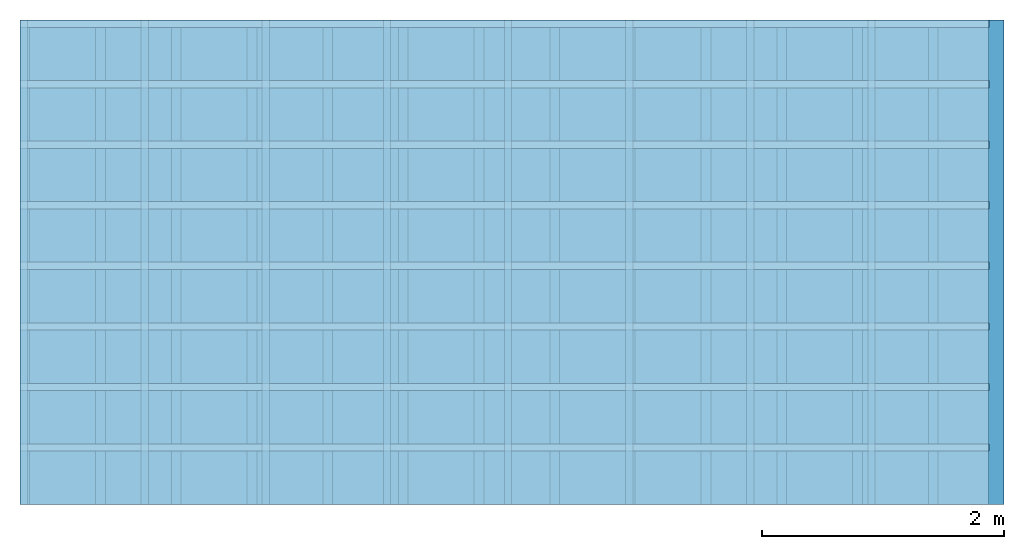
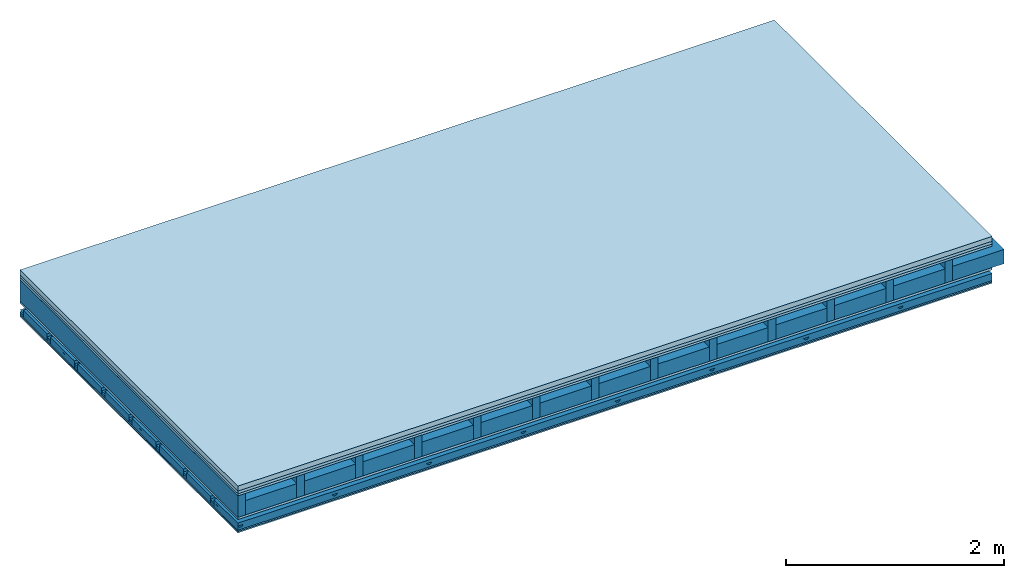
# One storey: 6 plates, 5 members, 1 element without a shape of its own.
"""IFC4 building model written with IfcOpenShell, lengths in metres."""

from ifc_helpers import new_model, si_unit, derived_unit, direction, frame, frame_2d, origin, origin_with_axes, place, context, project, spatial, polyline, rectangle, outline, extrude, material, layer, layer_set, type_object, element, aggregate, save


model = new_model("IFC4")

# Units and contexts
plan_context = context("Plan", 3, precision=1e-05, world=origin(), true_north=direction((0.0, 1.0)))
model_context = context("Model", 3, precision=1e-05, world=origin(), true_north=direction((0.0, 1.0)))
ifc_project = project(units=[si_unit("LENGTHUNIT", "METRE"), derived_unit("SOUNDPRESSUREUNIT", [(si_unit("PRESSUREUNIT", "PASCAL", prefix="MICRO"), 0)]), si_unit("ENERGYUNIT", "JOULE", prefix="MEGA"), si_unit("MASSUNIT", "GRAM", prefix="KILO"), derived_unit("THERMALTRANSMITTANCEUNIT", [(si_unit("POWERUNIT", "WATT"), 1), (si_unit("AREAUNIT", "SQUARE_METRE"), -1), (si_unit("THERMODYNAMICTEMPERATUREUNIT", "KELVIN"), -1)]), derived_unit("AREADENSITYUNIT", [(si_unit("MASSUNIT", "GRAM", prefix="KILO"), 1), (si_unit("AREAUNIT", "SQUARE_METRE"), -1)]), derived_unit("USERDEFINED", [(si_unit("ENERGYUNIT", "JOULE", prefix="MEGA"), 1), (si_unit("AREAUNIT", "SQUARE_METRE"), -1)])], contexts=[plan_context, model_context])

# Site, building, storey
site = spatial("IfcSite", under=ifc_project)
building_placement = place(None, origin())
building = spatial("IfcBuilding", under=site, at=building_placement)
storey_placement = place(building_placement, origin())
storey = spatial("IfcBuildingStorey", under=building, at=storey_placement)

# Slab, members, plates
ifc_material_1 = material(Category="04.005")
ifc_layer_1 = layer(ifc_material_1, 0.055, Name="On-material")
ifc_material_2 = material()
ifc_layer_2 = layer(ifc_material_2, 0.03, Name="Impact sound insulation")
ifc_material_3 = material(Category="07.001")
ifc_layer_3 = layer(ifc_material_3, 0.025, Name="Sub-floor")
ifc_material_4 = material(Name="Rigid, of the art")
ifc_layer_4 = layer(ifc_material_4, 0.0, Name="Bond")
ifc_layer_5 = layer(None, 0.24, Name="Supporting structure")
ifc_layer_6 = layer(ifc_material_4, 0.0, Name="Bond")
ifc_layer_7 = layer(ifc_material_3, 0.025, Name="Lower layer 1")
ifc_layer_8 = layer(None, 0.093, Name="Coupling")
ifc_layer_9 = layer(None, 0.027, Name="Battens / profiles")
ifc_material_5 = material(Name="Plasterboard type A", Category="03.008")
ifc_layer_10 = layer(ifc_material_5, 0.015, Name="Ceiling covering 1st layer")
ifc_layer_11 = layer(ifc_material_5, 0.015, Name="Ceiling covering layer 2")
ifc_material_6 = material(Name="joints", Category="04.017")
ifc_layer_12 = layer(ifc_material_6, 0.0, Name="Surface / treatment")
ifc_layer_set = layer_set([ifc_layer_1, ifc_layer_2, ifc_layer_3, ifc_layer_4, ifc_layer_5, ifc_layer_6, ifc_layer_7, ifc_layer_8, ifc_layer_9, ifc_layer_10, ifc_layer_11, ifc_layer_12])
slab_type = type_object("IfcSlabType", Name="A0825", PredefinedType="NOTDEFINED", material=ifc_layer_set)
slab_placement = place(None, frame((0.0, 0.0, 0.0), z_axis=(0.0, 0.0, -1.0), x_axis=(1.0, 0.0, 0.0)))
slab = element("IfcSlab", 1, at=slab_placement, inside=storey, type_object=slab_type, material=ifc_layer_set, Name="Slab #1")
ifc_material_7 = material()
member_1_placement = place(slab_placement, origin())
member_1 = element("IfcMember", 2, at=member_1_placement, material=ifc_material_7, Name="Supporting structure", context=plan_context, shape_type="SweptSolid", body=[
    extrude(rectangle(XDim=0.08, YDim=0.24, at=frame_2d((0.04, 0.12), x_axis=(1.0, 0.0))), frame((0.0, 4.0, 0.11), z_axis=(0.0, -1.0, 0.0), x_axis=(1.0, 0.0, 0.0)), (0.0, 0.0, 1.0), 4.0),
    extrude(rectangle(XDim=0.08, YDim=0.24, at=frame_2d((0.04, 0.12), x_axis=(1.0, 0.0))), frame((0.625, 4.0, 0.11), z_axis=(0.0, -1.0, 0.0), x_axis=(1.0, 0.0, 0.0)), (0.0, 0.0, 1.0), 4.0),
    extrude(rectangle(XDim=0.08, YDim=0.24, at=frame_2d((0.04, 0.12), x_axis=(1.0, 0.0))), frame((1.25, 4.0, 0.11), z_axis=(0.0, -1.0, 0.0), x_axis=(1.0, 0.0, 0.0)), (0.0, 0.0, 1.0), 4.0),
    extrude(rectangle(XDim=0.08, YDim=0.24, at=frame_2d((0.04, 0.12), x_axis=(1.0, 0.0))), frame((1.875, 4.0, 0.11), z_axis=(0.0, -1.0, 0.0), x_axis=(1.0, 0.0, 0.0)), (0.0, 0.0, 1.0), 4.0),
    extrude(rectangle(XDim=0.08, YDim=0.24, at=frame_2d((0.04, 0.12), x_axis=(1.0, 0.0))), frame((2.5, 4.0, 0.11), z_axis=(0.0, -1.0, 0.0), x_axis=(1.0, 0.0, 0.0)), (0.0, 0.0, 1.0), 4.0),
    extrude(rectangle(XDim=0.08, YDim=0.24, at=frame_2d((0.04, 0.12), x_axis=(1.0, 0.0))), frame((3.125, 4.0, 0.11), z_axis=(0.0, -1.0, 0.0), x_axis=(1.0, 0.0, 0.0)), (0.0, 0.0, 1.0), 4.0),
    extrude(rectangle(XDim=0.08, YDim=0.24, at=frame_2d((0.04, 0.12), x_axis=(1.0, 0.0))), frame((3.75, 4.0, 0.11), z_axis=(0.0, -1.0, 0.0), x_axis=(1.0, 0.0, 0.0)), (0.0, 0.0, 1.0), 4.0),
    extrude(rectangle(XDim=0.08, YDim=0.24, at=frame_2d((0.04, 0.12), x_axis=(1.0, 0.0))), frame((4.375, 4.0, 0.11), z_axis=(0.0, -1.0, 0.0), x_axis=(1.0, 0.0, 0.0)), (0.0, 0.0, 1.0), 4.0),
    extrude(rectangle(XDim=0.08, YDim=0.24, at=frame_2d((0.04, 0.12), x_axis=(1.0, 0.0))), frame((5.0, 4.0, 0.11), z_axis=(0.0, -1.0, 0.0), x_axis=(1.0, 0.0, 0.0)), (0.0, 0.0, 1.0), 4.0),
    extrude(rectangle(XDim=0.08, YDim=0.24, at=frame_2d((0.04, 0.12), x_axis=(1.0, 0.0))), frame((5.625, 4.0, 0.11), z_axis=(0.0, -1.0, 0.0), x_axis=(1.0, 0.0, 0.0)), (0.0, 0.0, 1.0), 4.0),
    extrude(rectangle(XDim=0.08, YDim=0.24, at=frame_2d((0.04, 0.12), x_axis=(1.0, 0.0))), frame((6.25, 4.0, 0.11), z_axis=(0.0, -1.0, 0.0), x_axis=(1.0, 0.0, 0.0)), (0.0, 0.0, 1.0), 4.0),
    extrude(rectangle(XDim=0.08, YDim=0.24, at=frame_2d((0.04, 0.12), x_axis=(1.0, 0.0))), frame((6.875, 4.0, 0.11), z_axis=(0.0, -1.0, 0.0), x_axis=(1.0, 0.0, 0.0)), (0.0, 0.0, 1.0), 4.0),
    extrude(rectangle(XDim=0.08, YDim=0.24, at=frame_2d((0.04, 0.12), x_axis=(1.0, 0.0))), frame((7.5, 4.0, 0.11), z_axis=(0.0, -1.0, 0.0), x_axis=(1.0, 0.0, 0.0)), (0.0, 0.0, 1.0), 4.0),
])
ifc_material_8 = material()
member_2_placement = place(slab_placement, origin())
member_2 = element("IfcMember", 3, at=member_2_placement, material=ifc_material_8, Name="in supporting structure", context=plan_context, shape_type="SweptSolid", body=[
    extrude(rectangle(XDim=0.545, YDim=0.16, at=frame_2d((0.2725, 0.08), x_axis=(1.0, 0.0))), frame((0.08, 4.0, 0.19), z_axis=(0.0, -1.0, 0.0), x_axis=(1.0, 0.0, 0.0)), (0.0, 0.0, 1.0), 4.0),
    extrude(rectangle(XDim=0.545, YDim=0.16, at=frame_2d((0.2725, 0.08), x_axis=(1.0, 0.0))), frame((0.705, 4.0, 0.19), z_axis=(0.0, -1.0, 0.0), x_axis=(1.0, 0.0, 0.0)), (0.0, 0.0, 1.0), 4.0),
    extrude(rectangle(XDim=0.545, YDim=0.16, at=frame_2d((0.2725, 0.08), x_axis=(1.0, 0.0))), frame((1.33, 4.0, 0.19), z_axis=(0.0, -1.0, 0.0), x_axis=(1.0, 0.0, 0.0)), (0.0, 0.0, 1.0), 4.0),
    extrude(rectangle(XDim=0.545, YDim=0.16, at=frame_2d((0.2725, 0.08), x_axis=(1.0, 0.0))), frame((1.955, 4.0, 0.19), z_axis=(0.0, -1.0, 0.0), x_axis=(1.0, 0.0, 0.0)), (0.0, 0.0, 1.0), 4.0),
    extrude(rectangle(XDim=0.545, YDim=0.16, at=frame_2d((0.2725, 0.08), x_axis=(1.0, 0.0))), frame((2.58, 4.0, 0.19), z_axis=(0.0, -1.0, 0.0), x_axis=(1.0, 0.0, 0.0)), (0.0, 0.0, 1.0), 4.0),
    extrude(rectangle(XDim=0.545, YDim=0.16, at=frame_2d((0.2725, 0.08), x_axis=(1.0, 0.0))), frame((3.205, 4.0, 0.19), z_axis=(0.0, -1.0, 0.0), x_axis=(1.0, 0.0, 0.0)), (0.0, 0.0, 1.0), 4.0),
    extrude(rectangle(XDim=0.545, YDim=0.16, at=frame_2d((0.2725, 0.08), x_axis=(1.0, 0.0))), frame((3.83, 4.0, 0.19), z_axis=(0.0, -1.0, 0.0), x_axis=(1.0, 0.0, 0.0)), (0.0, 0.0, 1.0), 4.0),
    extrude(rectangle(XDim=0.545, YDim=0.16, at=frame_2d((0.2725, 0.08), x_axis=(1.0, 0.0))), frame((4.455, 4.0, 0.19), z_axis=(0.0, -1.0, 0.0), x_axis=(1.0, 0.0, 0.0)), (0.0, 0.0, 1.0), 4.0),
    extrude(rectangle(XDim=0.545, YDim=0.16, at=frame_2d((0.2725, 0.08), x_axis=(1.0, 0.0))), frame((5.08, 4.0, 0.19), z_axis=(0.0, -1.0, 0.0), x_axis=(1.0, 0.0, 0.0)), (0.0, 0.0, 1.0), 4.0),
    extrude(rectangle(XDim=0.545, YDim=0.16, at=frame_2d((0.2725, 0.08), x_axis=(1.0, 0.0))), frame((5.705, 4.0, 0.19), z_axis=(0.0, -1.0, 0.0), x_axis=(1.0, 0.0, 0.0)), (0.0, 0.0, 1.0), 4.0),
    extrude(rectangle(XDim=0.545, YDim=0.16, at=frame_2d((0.2725, 0.08), x_axis=(1.0, 0.0))), frame((6.33, 4.0, 0.19), z_axis=(0.0, -1.0, 0.0), x_axis=(1.0, 0.0, 0.0)), (0.0, 0.0, 1.0), 4.0),
    extrude(rectangle(XDim=0.545, YDim=0.16, at=frame_2d((0.2725, 0.08), x_axis=(1.0, 0.0))), frame((6.955, 4.0, 0.19), z_axis=(0.0, -1.0, 0.0), x_axis=(1.0, 0.0, 0.0)), (0.0, 0.0, 1.0), 4.0),
    extrude(rectangle(XDim=0.545, YDim=0.16, at=frame_2d((0.2725, 0.08), x_axis=(1.0, 0.0))), frame((7.58, 4.0, 0.19), z_axis=(0.0, -1.0, 0.0), x_axis=(1.0, 0.0, 0.0)), (0.0, 0.0, 1.0), 4.0),
])
ifc_material_9 = material()
member_3_placement = place(slab_placement, origin())
member_3 = element("IfcMember", 4, at=member_3_placement, material=ifc_material_9, Name="Coupling", context=plan_context, shape_type="SweptSolid", body=[
    extrude(outline(polyline([(0.0, 0.0), (0.06, 0.0), (0.04, 0.02), (0.02, 0.02), (0.0, 0.0)])), frame((0.0, 4.0, 0.448), z_axis=(0.0, -1.0, 0.0), x_axis=(1.0, 0.0, 0.0)), (0.0, 0.0, 1.0), 4.0),
    extrude(outline(polyline([(0.0, 0.0), (0.06, 0.0), (0.04, 0.02), (0.02, 0.02), (0.0, 0.0)])), frame((1.0, 4.0, 0.448), z_axis=(0.0, -1.0, 0.0), x_axis=(1.0, 0.0, 0.0)), (0.0, 0.0, 1.0), 4.0),
    extrude(outline(polyline([(0.0, 0.0), (0.06, 0.0), (0.04, 0.02), (0.02, 0.02), (0.0, 0.0)])), frame((2.0, 4.0, 0.448), z_axis=(0.0, -1.0, 0.0), x_axis=(1.0, 0.0, 0.0)), (0.0, 0.0, 1.0), 4.0),
    extrude(outline(polyline([(0.0, 0.0), (0.06, 0.0), (0.04, 0.02), (0.02, 0.02), (0.0, 0.0)])), frame((3.0, 4.0, 0.448), z_axis=(0.0, -1.0, 0.0), x_axis=(1.0, 0.0, 0.0)), (0.0, 0.0, 1.0), 4.0),
    extrude(outline(polyline([(0.0, 0.0), (0.06, 0.0), (0.04, 0.02), (0.02, 0.02), (0.0, 0.0)])), frame((4.0, 4.0, 0.448), z_axis=(0.0, -1.0, 0.0), x_axis=(1.0, 0.0, 0.0)), (0.0, 0.0, 1.0), 4.0),
    extrude(outline(polyline([(0.0, 0.0), (0.06, 0.0), (0.04, 0.02), (0.02, 0.02), (0.0, 0.0)])), frame((5.0, 4.0, 0.448), z_axis=(0.0, -1.0, 0.0), x_axis=(1.0, 0.0, 0.0)), (0.0, 0.0, 1.0), 4.0),
    extrude(outline(polyline([(0.0, 0.0), (0.06, 0.0), (0.04, 0.02), (0.02, 0.02), (0.0, 0.0)])), frame((6.0, 4.0, 0.448), z_axis=(0.0, -1.0, 0.0), x_axis=(1.0, 0.0, 0.0)), (0.0, 0.0, 1.0), 4.0),
    extrude(outline(polyline([(0.0, 0.0), (0.06, 0.0), (0.04, 0.02), (0.02, 0.02), (0.0, 0.0)])), frame((7.0, 4.0, 0.448), z_axis=(0.0, -1.0, 0.0), x_axis=(1.0, 0.0, 0.0)), (0.0, 0.0, 1.0), 4.0),
])
ifc_material_10 = material()
member_4_placement = place(slab_placement, origin())
member_4 = element("IfcMember", 5, at=member_4_placement, material=ifc_material_10, Name="Battens / profiles", context=plan_context, shape_type="SweptSolid", body=[
    extrude(rectangle(XDim=0.06, YDim=0.027, at=frame_2d((0.03, 0.0135), x_axis=(1.0, 0.0))), frame((0.0, 0.0, 0.468), z_axis=(1.0, 0.0, 0.0), x_axis=(0.0, 1.0, 0.0)), (0.0, 0.0, 1.0), 8.0),
    extrude(rectangle(XDim=0.06, YDim=0.027, at=frame_2d((0.03, 0.0135), x_axis=(1.0, 0.0))), frame((0.0, 0.5, 0.468), z_axis=(1.0, 0.0, 0.0), x_axis=(0.0, 1.0, 0.0)), (0.0, 0.0, 1.0), 8.0),
    extrude(rectangle(XDim=0.06, YDim=0.027, at=frame_2d((0.03, 0.0135), x_axis=(1.0, 0.0))), frame((0.0, 1.0, 0.468), z_axis=(1.0, 0.0, 0.0), x_axis=(0.0, 1.0, 0.0)), (0.0, 0.0, 1.0), 8.0),
    extrude(rectangle(XDim=0.06, YDim=0.027, at=frame_2d((0.03, 0.0135), x_axis=(1.0, 0.0))), frame((0.0, 1.5, 0.468), z_axis=(1.0, 0.0, 0.0), x_axis=(0.0, 1.0, 0.0)), (0.0, 0.0, 1.0), 8.0),
    extrude(rectangle(XDim=0.06, YDim=0.027, at=frame_2d((0.03, 0.0135), x_axis=(1.0, 0.0))), frame((0.0, 2.0, 0.468), z_axis=(1.0, 0.0, 0.0), x_axis=(0.0, 1.0, 0.0)), (0.0, 0.0, 1.0), 8.0),
    extrude(rectangle(XDim=0.06, YDim=0.027, at=frame_2d((0.03, 0.0135), x_axis=(1.0, 0.0))), frame((0.0, 2.5, 0.468), z_axis=(1.0, 0.0, 0.0), x_axis=(0.0, 1.0, 0.0)), (0.0, 0.0, 1.0), 8.0),
    extrude(rectangle(XDim=0.06, YDim=0.027, at=frame_2d((0.03, 0.0135), x_axis=(1.0, 0.0))), frame((0.0, 3.0, 0.468), z_axis=(1.0, 0.0, 0.0), x_axis=(0.0, 1.0, 0.0)), (0.0, 0.0, 1.0), 8.0),
    extrude(rectangle(XDim=0.06, YDim=0.027, at=frame_2d((0.03, 0.0135), x_axis=(1.0, 0.0))), frame((0.0, 3.5, 0.468), z_axis=(1.0, 0.0, 0.0), x_axis=(0.0, 1.0, 0.0)), (0.0, 0.0, 1.0), 8.0),
])
ifc_material_11 = material()
member_5_placement = place(slab_placement, origin())
member_5 = element("IfcMember", 6, at=member_5_placement, material=ifc_material_11, Name="Cavity", context=plan_context, shape_type="SweptSolid", body=[
    extrude(rectangle(XDim=0.44, YDim=0.08, at=frame_2d((0.22, 0.04), x_axis=(1.0, 0.0))), frame((0.0, 0.06, 0.415), z_axis=(1.0, 0.0, 0.0), x_axis=(0.0, 1.0, 0.0)), (0.0, 0.0, 1.0), 8.0),
    extrude(rectangle(XDim=0.44, YDim=0.08, at=frame_2d((0.22, 0.04), x_axis=(1.0, 0.0))), frame((0.0, 0.56, 0.415), z_axis=(1.0, 0.0, 0.0), x_axis=(0.0, 1.0, 0.0)), (0.0, 0.0, 1.0), 8.0),
    extrude(rectangle(XDim=0.44, YDim=0.08, at=frame_2d((0.22, 0.04), x_axis=(1.0, 0.0))), frame((0.0, 1.06, 0.415), z_axis=(1.0, 0.0, 0.0), x_axis=(0.0, 1.0, 0.0)), (0.0, 0.0, 1.0), 8.0),
    extrude(rectangle(XDim=0.44, YDim=0.08, at=frame_2d((0.22, 0.04), x_axis=(1.0, 0.0))), frame((0.0, 1.56, 0.415), z_axis=(1.0, 0.0, 0.0), x_axis=(0.0, 1.0, 0.0)), (0.0, 0.0, 1.0), 8.0),
    extrude(rectangle(XDim=0.44, YDim=0.08, at=frame_2d((0.22, 0.04), x_axis=(1.0, 0.0))), frame((0.0, 2.06, 0.415), z_axis=(1.0, 0.0, 0.0), x_axis=(0.0, 1.0, 0.0)), (0.0, 0.0, 1.0), 8.0),
    extrude(rectangle(XDim=0.44, YDim=0.08, at=frame_2d((0.22, 0.04), x_axis=(1.0, 0.0))), frame((0.0, 2.56, 0.415), z_axis=(1.0, 0.0, 0.0), x_axis=(0.0, 1.0, 0.0)), (0.0, 0.0, 1.0), 8.0),
    extrude(rectangle(XDim=0.44, YDim=0.08, at=frame_2d((0.22, 0.04), x_axis=(1.0, 0.0))), frame((0.0, 3.06, 0.415), z_axis=(1.0, 0.0, 0.0), x_axis=(0.0, 1.0, 0.0)), (0.0, 0.0, 1.0), 8.0),
    extrude(rectangle(XDim=0.44, YDim=0.08, at=frame_2d((0.22, 0.04), x_axis=(1.0, 0.0))), frame((0.0, 3.56, 0.415), z_axis=(1.0, 0.0, 0.0), x_axis=(0.0, 1.0, 0.0)), (0.0, 0.0, 1.0), 8.0),
])
plate_1_placement = place(slab_placement, origin())
plate_1 = element("IfcPlate", 7, at=plate_1_placement, material=ifc_material_1, Name="On-material", context=plan_context, shape_type="SweptSolid", body=[
    extrude(rectangle(XDim=8.0, YDim=4.0, at=frame_2d((4.0, 2.0), x_axis=(1.0, 0.0))), origin_with_axes(), (0.0, 0.0, 1.0), 0.055),
])
plate_2_placement = place(slab_placement, origin())
plate_2 = element("IfcPlate", 8, at=plate_2_placement, material=ifc_material_2, Name="Impact sound insulation", context=plan_context, shape_type="SweptSolid", body=[
    extrude(rectangle(XDim=8.0, YDim=4.0, at=frame_2d((4.0, 2.0), x_axis=(1.0, 0.0))), frame((0.0, 0.0, 0.055), z_axis=(0.0, 0.0, 1.0), x_axis=(1.0, 0.0, 0.0)), (0.0, 0.0, 1.0), 0.03),
])
plate_3_placement = place(slab_placement, origin())
plate_3 = element("IfcPlate", 9, at=plate_3_placement, material=ifc_material_3, Name="Sub-floor", context=plan_context, shape_type="SweptSolid", body=[
    extrude(rectangle(XDim=8.0, YDim=4.0, at=frame_2d((4.0, 2.0), x_axis=(1.0, 0.0))), frame((0.0, 0.0, 0.085), z_axis=(0.0, 0.0, 1.0), x_axis=(1.0, 0.0, 0.0)), (0.0, 0.0, 1.0), 0.025),
])
plate_4_placement = place(slab_placement, origin())
plate_4 = element("IfcPlate", 10, at=plate_4_placement, material=ifc_material_3, Name="Lower layer 1", context=plan_context, shape_type="SweptSolid", body=[
    extrude(rectangle(XDim=8.0, YDim=4.0, at=frame_2d((4.0, 2.0), x_axis=(1.0, 0.0))), frame((0.0, 0.0, 0.35), z_axis=(0.0, 0.0, 1.0), x_axis=(1.0, 0.0, 0.0)), (0.0, 0.0, 1.0), 0.025),
])
plate_5_placement = place(slab_placement, origin())
plate_5 = element("IfcPlate", 11, at=plate_5_placement, material=ifc_material_5, Name="Ceiling covering 1st layer", context=plan_context, shape_type="SweptSolid", body=[
    extrude(rectangle(XDim=8.0, YDim=4.0, at=frame_2d((4.0, 2.0), x_axis=(1.0, 0.0))), frame((0.0, 0.0, 0.495), z_axis=(0.0, 0.0, 1.0), x_axis=(1.0, 0.0, 0.0)), (0.0, 0.0, 1.0), 0.015),
])
plate_6_placement = place(slab_placement, origin())
plate_6 = element("IfcPlate", 12, at=plate_6_placement, material=ifc_material_5, Name="Ceiling covering layer 2", context=plan_context, shape_type="SweptSolid", body=[
    extrude(rectangle(XDim=8.0, YDim=4.0, at=frame_2d((4.0, 2.0), x_axis=(1.0, 0.0))), frame((0.0, 0.0, 0.51), z_axis=(0.0, 0.0, 1.0), x_axis=(1.0, 0.0, 0.0)), (0.0, 0.0, 1.0), 0.015),
])
aggregate(slab, [plate_1, plate_2, plate_3, member_1, member_2, plate_4, member_3, member_4, member_5, plate_5, plate_6])

save(model, "model.ifc")
